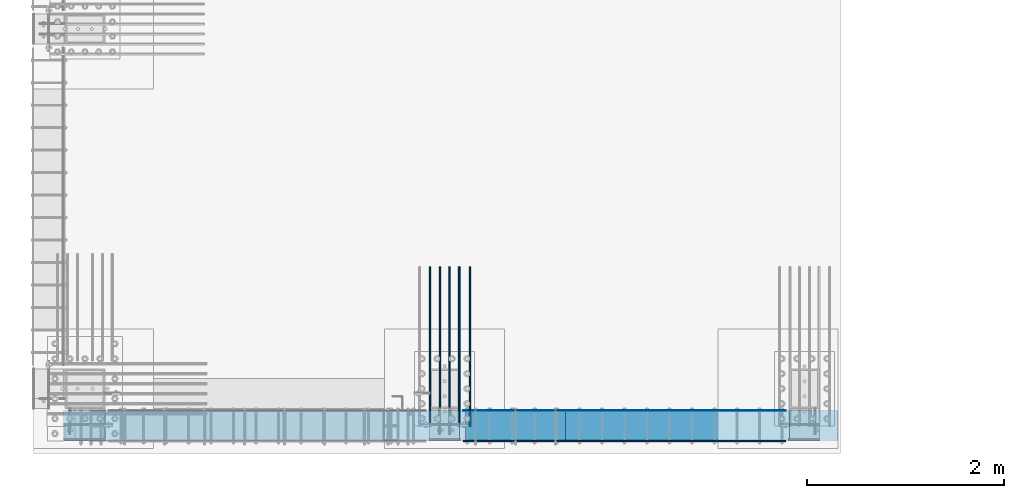
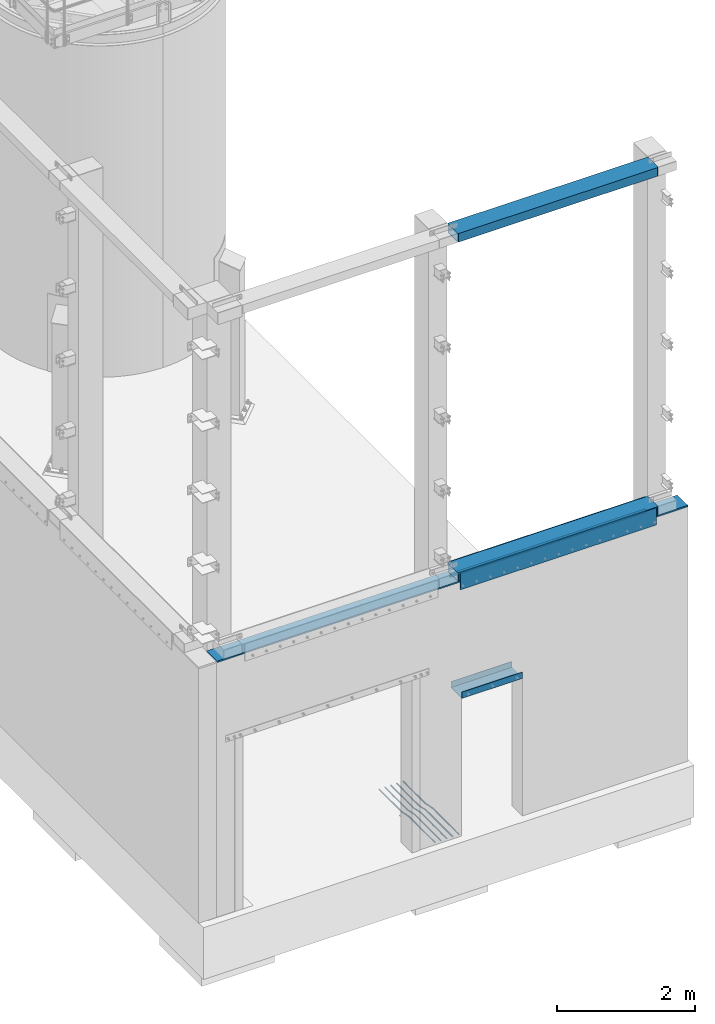
# One storey, part 909 of 1876: 12 beams, 6 elements without a shape of their own.
"""IFC2X3 building model written with IfcOpenShell, lengths in millimetres."""

from ifc_helpers import new_model, si_unit, frame, origin_with_axes, place, context, subcontext, project, spatial, faceted_brep, material, type_object, element, aggregate, save


model = new_model("IFC2X3")

# Units and contexts
model_context = context("Model", 3, precision=1e-05, world=origin_with_axes())
body_context = subcontext(model_context, "Body", "Model", "MODEL_VIEW")
ifc_project = project(units=[si_unit("LENGTHUNIT", "METRE", prefix="MILLI"), si_unit("AREAUNIT", "SQUARE_METRE"), si_unit("VOLUMEUNIT", "CUBIC_METRE"), si_unit("MASSUNIT", "GRAM", prefix="KILO"), si_unit("TIMEUNIT", "SECOND"), si_unit("PLANEANGLEUNIT", "RADIAN"), si_unit("SOLIDANGLEUNIT", "STERADIAN"), si_unit("THERMODYNAMICTEMPERATUREUNIT", "DEGREE_CELSIUS"), si_unit("LUMINOUSINTENSITYUNIT", "LUMEN")], contexts=[model_context])

# Site, building, storey
site_placement = place(None, origin_with_axes())
site = spatial("IfcSite", under=ifc_project, at=site_placement, CompositionType="ELEMENT")
building_placement = place(site_placement, origin_with_axes())
building = spatial("IfcBuilding", under=site, at=building_placement, Name="Undefined", CompositionType="ELEMENT")
storey_placement = place(building_placement, origin_with_axes())
storey = spatial("IfcBuildingStorey", under=building, at=storey_placement, Name="Undefined", CompositionType="ELEMENT", Elevation=0.0)

# Assembly, beam
assembly_1_placement = place(storey_placement, origin_with_axes())
assembly_1 = element("IfcElementAssembly", 1, at=assembly_1_placement, inside=storey, Name="BEAM", AssemblyPlace="NOTDEFINED", PredefinedType="RIGID_FRAME")
ifc_material_1 = material()
beam_type_1 = type_object("IfcBeamType", Name="HSS12X6X1/2", PredefinedType="NOTDEFINED")
beam_1_placement = place(assembly_1_placement, frame((4041.775, -25771.475, 10591.8), z_axis=(0.0, 1.0, 0.0), x_axis=(1.0, 0.0, 0.0)))
beam_1 = element("IfcBeam", 2, at=beam_1_placement, type_object=beam_type_1, material=ifc_material_1, Name="BEAM", ObjectType="HSS12X6X1/2", context=body_context, shape_type="Brep", body=[
    faceted_brep([(0.0, 76.2000000000007, -139.699999999812), (0.0, 63.5, -139.7), (0.0, 63.5, 139.7), (0.0, 76.2000000000007, 139.700000000026), (0.0, -63.5, -139.7), (3352.8, -63.5, -139.7), (3352.8, 63.5, -139.7), (3340.1, 76.2000000000007, -152.4), (3352.8, 76.2000000000007, -139.7), (3352.8, -76.2000000000007, -139.7), (3340.1, -76.2000000000007, -152.4), (12.7000000000025, -76.2000000000007, -152.4), (12.7000000000025, 76.2000000000007, -152.4), (12.6999999999734, 76.2000000000007, 152.4), (3340.1, 76.2000000000007, 152.4), (3352.8, 76.2000000000007, 139.7), (3352.8, 63.5, 139.7), (0.0, -63.5, 139.7), (3352.8, -63.5, 139.7), (0.0, -76.2000000000007, 139.700000000026), (12.6999999999734, -76.2000000000007, 152.4), (3340.1, -76.2000000000007, 152.4), (3352.8, -76.2000000000007, 139.7), (0.0, -76.2000000000007, -139.699999999812)], [[[0, 1, 2, 3]], [[1, 4, 5, 6]], [[7, 8, 6, 5, 9, 10]], [[11, 12, 7, 10]], [[8, 7, 12, 0, 3, 13, 14, 15]], [[6, 8, 15, 16]], [[2, 1, 6, 16]], [[17, 2, 16, 18]], [[3, 2, 17, 19, 20, 13]], [[13, 20, 21, 14]], [[16, 15, 14, 21, 22, 18]], [[9, 5, 18, 22]], [[4, 17, 18, 5]], [[4, 23, 19, 17]], [[20, 19, 23, 11, 10, 9, 22, 21]], [[4, 1, 0, 12, 11, 23]]]),
])
aggregate(assembly_1, [beam_1])

assembly_2_placement = place(storey_placement, origin_with_axes())
assembly_2 = element("IfcElementAssembly", 3, at=assembly_2_placement, inside=storey, Name="BEAM", AssemblyPlace="NOTDEFINED", PredefinedType="RIGID_FRAME")
beam_2_placement = place(assembly_2_placement, frame((4041.775, -25771.475, 4597.4), z_axis=(0.0, 1.0, 0.0), x_axis=(1.0, 0.0, 0.0)))
beam_2 = element("IfcBeam", 4, at=beam_2_placement, type_object=beam_type_1, material=ifc_material_1, Name="BEAM", ObjectType="HSS12X6X1/2", context=body_context, shape_type="Brep", body=[
    faceted_brep([(0.0, -63.5, 139.7), (0.0, 63.5, 139.7), (3352.8, 63.5, 139.7), (3352.8, -63.5, 139.7), (0.0, 76.2000000000007, -139.699999999812), (0.0, 63.5, -139.7), (0.0, 76.2000000000007, 139.700000000026), (0.0, -63.5, -139.7), (12.7000000000025, 76.2000000000007, -152.4), (12.7000000000025, -76.2000000000007, -152.4), (0.0, -76.2000000000007, -139.699999999812), (0.0, -76.2000000000007, 139.700000000026), (12.6999999999734, -76.2000000000007, 152.4), (12.6999999999734, 76.2000000000007, 152.4), (3340.1, -76.2000000000007, 152.4), (3340.1, 76.2000000000007, 152.4), (3352.8, 76.2000000000007, 139.7), (3352.8, -76.2000000000007, 139.7), (3352.8, -76.2000000000007, -139.7), (3352.8, -63.5, -139.7), (3352.8, 63.5, -139.7), (3352.8, 76.2000000000007, -139.7), (3340.1, 76.2000000000007, -152.4), (3340.1, -76.2000000000007, -152.4)], [[[0, 1, 2, 3]], [[4, 5, 1, 6]], [[7, 5, 4, 8, 9, 10]], [[7, 10, 11, 0]], [[6, 1, 0, 11, 12, 13]], [[13, 12, 14, 15]], [[2, 16, 15, 14, 17, 3]], [[18, 19, 3, 17]], [[7, 0, 3, 19]], [[5, 7, 19, 20]], [[1, 5, 20, 2]], [[20, 21, 16, 2]], [[21, 22, 8, 4, 6, 13, 15, 16]], [[9, 8, 22, 23]], [[12, 11, 10, 9, 23, 18, 17, 14]], [[22, 21, 20, 19, 18, 23]]]),
])

# Assembly, beams
assembly_3_placement = place(storey_placement, origin_with_axes())
assembly_3 = element("IfcElementAssembly", 5, at=assembly_3_placement, inside=storey, Name="PLATE", AssemblyPlace="NOTDEFINED", PredefinedType="RIGID_FRAME")
ifc_material_2 = material(Name="STEEL/A36")
beam_type_2 = type_object("IfcBeamType", PredefinedType="NOTDEFINED")
beam_3_placement = place(assembly_3_placement, frame((7356.47500038147, -25623.044, 4432.3), z_axis=(0.0, 0.0, 1.0), x_axis=(-1.0, 0.0, 0.0)))
beam_3 = element("IfcBeam", 6, at=beam_3_placement, type_object=beam_type_2, material=ifc_material_2, Name="PLATE", context=body_context, shape_type="Brep", body=[
    faceted_brep([(0.0, 3.969, -38.1000000000004), (0.0, 3.969, 38.1000000000004), (3276.6, 3.96900000000096, 38.1000000000004), (3276.6, 3.96900000000096, -38.1000000000004), (0.0, -3.969, 38.1000000000004), (3276.6, -3.96900000000096, 38.1000000000004), (0.0, -3.969, -38.1000000000004), (3276.6, -3.96900000000096, -38.1000000000004)], [[[0, 1, 2, 3]], [[1, 4, 5, 2]], [[4, 6, 7, 5]], [[6, 0, 3, 7]], [[5, 7, 3, 2]], [[6, 4, 1, 0]]]),
])
beam_type_3 = type_object("IfcBeamType", PredefinedType="NOTDEFINED")
beam_4_placement = place(assembly_3_placement, frame((7356.475, -25612.725, 4521.2), z_axis=(0.0, 0.0, 1.0), x_axis=(-1.0, 0.0, 0.0)))
beam_4 = element("IfcBeam", 7, at=beam_4_placement, type_object=beam_type_3, material=ifc_material_2, Name="PLATE", context=body_context, shape_type="Brep", body=[
    faceted_brep([(0.0, 6.35000000000002, -152.4), (0.0, 6.35000000000002, 152.4), (3276.6, 6.35000000000002, 152.4), (3276.6, 6.35000000000002, -152.4), (0.0, -6.35000000000002, 152.4), (3276.6, -6.35000000000002, 152.4), (0.0, -6.35000000000002, -152.4), (3276.6, -6.35000000000002, -152.4)], [[[0, 1, 2, 3]], [[1, 4, 5, 2]], [[4, 6, 7, 5]], [[6, 0, 3, 7]], [[5, 7, 3, 2]], [[6, 4, 1, 0]]]),
])
aggregate(assembly_3, [beam_3, beam_4])

# Beam
beam_5_placement = place(assembly_2_placement, frame((7356.475, -25930.225, 4521.2), z_axis=(0.0, 0.0, 1.0), x_axis=(-1.0, 0.0, 0.0)))
beam_5 = element("IfcBeam", 8, at=beam_5_placement, type_object=beam_type_3, material=ifc_material_2, Name="PLATE", context=body_context, shape_type="Brep", body=[
    faceted_brep([(0.0, 6.35000000000002, -152.4), (0.0, 6.35000000000002, 152.4), (3276.6, 6.35000000000002, 152.4), (3276.6, 6.35000000000002, -152.4), (0.0, -6.35000000000002, 152.4), (3276.6, -6.35000000000002, 152.4), (0.0, -6.35000000000002, -152.4), (3276.6, -6.35000000000002, -152.4)], [[[0, 1, 2, 3]], [[1, 4, 5, 2]], [[4, 6, 7, 5]], [[6, 0, 3, 7]], [[5, 7, 3, 2]], [[6, 4, 1, 0]]]),
])

aggregate(assembly_2, [beam_5, beam_2])

# Assembly, beams
assembly_4_placement = place(storey_placement, origin_with_axes())
assembly_4 = element("IfcElementAssembly", 9, at=assembly_4_placement, inside=storey, Name="PLATE", AssemblyPlace="NOTDEFINED", PredefinedType="RIGID_FRAME")
ifc_material_3 = material(Name="STEEL/A706-GR.60")
beam_type_4 = type_object("IfcBeamType", Name="5 REBAR", PredefinedType="NOTDEFINED")
beam_6_placement = place(assembly_4_placement, frame((3741.73752441406, -25781.0, -71.4374999999993), z_axis=(-1.0, 0.0, 0.0), x_axis=(0.0, 1.0, 0.0)))
beam_6 = element("IfcBeam", 10, at=beam_6_placement, type_object=beam_type_4, material=ifc_material_3, Name="REBAR", ObjectType="5 REBAR", context=body_context, shape_type="Brep", body=[
    faceted_brep([(0.0, -7.9375, 0.0), (0.0, -5.61266007566822, -5.61266007566883), (760.672013570867, -5.61266007566822, -5.61266007566837), (760.672013570867, -7.9375, 0.0), (0.0, 0.0, -7.9375), (760.672013570867, 0.0, -7.9375), (0.0, 5.61266007566822, -5.61266007566883), (760.672013570867, 5.61266007566822, -5.61266007566837), (0.0, 7.9375, 0.0), (760.672013570867, 7.9375, 0.0), (0.0, 5.61266007566822, 5.61266007566883), (760.672013570867, 5.61266007566822, 5.61266007566837), (0.0, 0.0, 7.9375), (760.672013570867, 0.0, 7.9375), (0.0, -5.61266007566822, 5.61266007566883), (760.672013570867, -5.61266007566822, 5.61266007566837), (762.585579012299, -5.61266007566822, -5.61266007566837), (762.828108499445, -7.9375, 0.0), (762.000061035156, 0.0, -7.9375), (761.414543058014, 5.61266007566822, -5.61266007566837), (761.172013570867, 7.9375, 0.0), (761.414543058014, 5.61266007566822, 5.61266007566837), (762.000061035156, 0.0, 7.9375), (762.585579012299, -5.61266007566822, 5.61266007566837), (764.4579427221, -5.21770838638834, -5.61266007566837), (764.937779698426, -7.49249126611924, 0.0), (763.299513786125, 0.274103293312095, -7.9375), (762.141084850151, 5.76591497301254, -5.61266007566837), (761.661247873824, 8.04069785274343, 0.0), (762.141084850151, 5.76591497301254, 5.61266007566837), (763.299513786125, 0.274103293312095, 7.9375), (764.4579427221, -5.21770838638834, 5.61266007566837), (965.059049427193, 37.096584264048, -5.61266007566837), (965.538886403519, 34.8218013843171, 0.0), (963.900620491218, 42.5883959437484, -7.9375), (962.742191555244, 48.0802076234489, -5.61266007566837), (962.262354578917, 50.3549905031798, 0.0), (962.742191555244, 48.0802076234489, 5.61266007566837), (963.900620491218, 42.5883959437484, 7.9375), (965.059049427193, 37.096584264048, 5.61266007566837), (965.78559121933, 37.2498391613923, -5.61266007566837), (966.028120706476, 34.9249992370605, 0.0), (965.200073242188, 42.8624992370605, -7.9375), (964.614555265045, 48.4751593127288, -5.61266007566837), (964.372025777899, 50.7999992370606, 0.0), (964.614555265045, 48.4751593127288, 5.61266007566837), (965.200073242188, 42.8624992370605, 7.9375), (965.78559121933, 37.2498391613923, 5.61266007566837), (966.528120706476, 37.2498391613923, -5.61266007566837), (966.528120706476, 34.9249992370605, 0.0), (966.528120706476, 42.8624992370605, -7.9375), (966.528120706476, 48.4751593127288, -5.61266007566837), (966.528120706476, 50.7999992370605, 0.0), (966.528120706476, 48.4751593127288, 5.61266007566837), (966.528120706476, 42.8624992370605, 7.9375), (966.528120706476, 37.2498391613923, 5.61266007566837), (1619.25, 37.2498391613923, -5.61266007566837), (1619.25, 34.9249992370605, 0.0), (1619.25, 42.8624992370605, -7.9375), (1619.25, 48.4751593127288, -5.61266007566837), (1619.25, 50.7999992370605, 0.0), (1619.25, 48.4751593127288, 5.61266007566837), (1619.25, 42.8624992370605, 7.9375), (1619.25, 37.2498391613923, 5.61266007566837)], [[[0, 1, 2, 3]], [[1, 4, 5, 2]], [[4, 6, 7, 5]], [[6, 8, 9, 7]], [[8, 10, 11, 9]], [[10, 12, 13, 11]], [[12, 14, 15, 13]], [[14, 0, 3, 15]], [[14, 12, 10, 8, 6, 4, 1, 0]], [[3, 2, 16, 17]], [[2, 5, 18, 16]], [[5, 7, 19, 18]], [[7, 9, 20, 19]], [[9, 11, 21, 20]], [[11, 13, 22, 21]], [[13, 15, 23, 22]], [[15, 3, 17, 23]], [[17, 16, 24, 25]], [[16, 18, 26, 24]], [[18, 19, 27, 26]], [[19, 20, 28, 27]], [[20, 21, 29, 28]], [[21, 22, 30, 29]], [[22, 23, 31, 30]], [[23, 17, 25, 31]], [[25, 24, 32, 33]], [[24, 26, 34, 32]], [[26, 27, 35, 34]], [[27, 28, 36, 35]], [[28, 29, 37, 36]], [[29, 30, 38, 37]], [[30, 31, 39, 38]], [[31, 25, 33, 39]], [[33, 32, 40, 41]], [[32, 34, 42, 40]], [[34, 35, 43, 42]], [[35, 36, 44, 43]], [[36, 37, 45, 44]], [[37, 38, 46, 45]], [[38, 39, 47, 46]], [[39, 33, 41, 47]], [[41, 40, 48, 49]], [[40, 42, 50, 48]], [[42, 43, 51, 50]], [[43, 44, 52, 51]], [[44, 45, 53, 52]], [[45, 46, 54, 53]], [[46, 47, 55, 54]], [[47, 41, 49, 55]], [[49, 48, 56, 57]], [[48, 50, 58, 56]], [[50, 51, 59, 58]], [[51, 52, 60, 59]], [[52, 53, 61, 60]], [[53, 54, 62, 61]], [[54, 55, 63, 62]], [[55, 49, 57, 63]], [[58, 59, 60, 61, 62, 63, 57, 56]]]),
])
beam_7_placement = place(assembly_4_placement, frame((4144.9625, -25781.0, -71.4374999999993), z_axis=(-1.0, 0.0, 0.0), x_axis=(0.0, 1.0, 0.0)))
beam_7 = element("IfcBeam", 11, at=beam_7_placement, type_object=beam_type_4, material=ifc_material_3, Name="REBAR", ObjectType="5 REBAR", context=body_context, shape_type="Brep", body=[
    faceted_brep([(0.0, -7.9375, 0.0), (0.0, -5.61266007566822, -5.61266007566883), (760.672013570867, -5.61266007566822, -5.61266007566837), (760.672013570867, -7.9375, 0.0), (0.0, 0.0, -7.9375), (760.672013570867, 0.0, -7.9375), (0.0, 5.61266007566822, -5.61266007566883), (760.672013570867, 5.61266007566822, -5.61266007566837), (0.0, 7.9375, 0.0), (760.672013570867, 7.9375, 0.0), (0.0, 5.61266007566822, 5.61266007566883), (760.672013570867, 5.61266007566822, 5.61266007566837), (0.0, 0.0, 7.9375), (760.672013570867, 0.0, 7.9375), (0.0, -5.61266007566822, 5.61266007566883), (760.672013570867, -5.61266007566822, 5.61266007566837), (762.585579012299, -5.61266007566822, -5.61266007566837), (762.828108499445, -7.9375, 0.0), (762.000061035156, 0.0, -7.9375), (761.414543058014, 5.61266007566822, -5.61266007566837), (761.172013570867, 7.9375, 0.0), (761.414543058014, 5.61266007566822, 5.61266007566837), (762.000061035156, 0.0, 7.9375), (762.585579012299, -5.61266007566822, 5.61266007566837), (764.4579427221, -5.21770838638834, -5.61266007566837), (764.937779698426, -7.49249126611924, 0.0), (763.299513786125, 0.274103293312095, -7.9375), (762.141084850151, 5.76591497301254, -5.61266007566837), (761.661247873824, 8.04069785274343, 0.0), (762.141084850151, 5.76591497301254, 5.61266007566837), (763.299513786125, 0.274103293312095, 7.9375), (764.4579427221, -5.21770838638834, 5.61266007566837), (965.059049427193, 37.096584264048, -5.61266007566837), (965.538886403519, 34.8218013843171, 0.0), (963.900620491218, 42.5883959437484, -7.9375), (962.742191555244, 48.0802076234489, -5.61266007566837), (962.262354578917, 50.3549905031798, 0.0), (962.742191555244, 48.0802076234489, 5.61266007566837), (963.900620491218, 42.5883959437484, 7.9375), (965.059049427193, 37.096584264048, 5.61266007566837), (965.78559121933, 37.2498391613923, -5.61266007566837), (966.028120706476, 34.9249992370605, 0.0), (965.200073242188, 42.8624992370605, -7.9375), (964.614555265045, 48.4751593127288, -5.61266007566837), (964.372025777899, 50.7999992370606, 0.0), (964.614555265045, 48.4751593127288, 5.61266007566837), (965.200073242188, 42.8624992370605, 7.9375), (965.78559121933, 37.2498391613923, 5.61266007566837), (966.528120706476, 37.2498391613923, -5.61266007566837), (966.528120706476, 34.9249992370605, 0.0), (966.528120706476, 42.8624992370605, -7.9375), (966.528120706476, 48.4751593127288, -5.61266007566837), (966.528120706476, 50.7999992370605, 0.0), (966.528120706476, 48.4751593127288, 5.61266007566837), (966.528120706476, 42.8624992370605, 7.9375), (966.528120706476, 37.2498391613923, 5.61266007566837), (1619.25, 37.2498391613923, -5.61266007566837), (1619.25, 34.9249992370605, 0.0), (1619.25, 42.8624992370605, -7.9375), (1619.25, 48.4751593127288, -5.61266007566837), (1619.25, 50.7999992370605, 0.0), (1619.25, 48.4751593127288, 5.61266007566837), (1619.25, 42.8624992370605, 7.9375), (1619.25, 37.2498391613923, 5.61266007566837)], [[[0, 1, 2, 3]], [[1, 4, 5, 2]], [[4, 6, 7, 5]], [[6, 8, 9, 7]], [[8, 10, 11, 9]], [[10, 12, 13, 11]], [[12, 14, 15, 13]], [[14, 0, 3, 15]], [[14, 12, 10, 8, 6, 4, 1, 0]], [[3, 2, 16, 17]], [[2, 5, 18, 16]], [[5, 7, 19, 18]], [[7, 9, 20, 19]], [[9, 11, 21, 20]], [[11, 13, 22, 21]], [[13, 15, 23, 22]], [[15, 3, 17, 23]], [[17, 16, 24, 25]], [[16, 18, 26, 24]], [[18, 19, 27, 26]], [[19, 20, 28, 27]], [[20, 21, 29, 28]], [[21, 22, 30, 29]], [[22, 23, 31, 30]], [[23, 17, 25, 31]], [[25, 24, 32, 33]], [[24, 26, 34, 32]], [[26, 27, 35, 34]], [[27, 28, 36, 35]], [[28, 29, 37, 36]], [[29, 30, 38, 37]], [[30, 31, 39, 38]], [[31, 25, 33, 39]], [[33, 32, 40, 41]], [[32, 34, 42, 40]], [[34, 35, 43, 42]], [[35, 36, 44, 43]], [[36, 37, 45, 44]], [[37, 38, 46, 45]], [[38, 39, 47, 46]], [[39, 33, 41, 47]], [[41, 40, 48, 49]], [[40, 42, 50, 48]], [[42, 43, 51, 50]], [[43, 44, 52, 51]], [[44, 45, 53, 52]], [[45, 46, 54, 53]], [[46, 47, 55, 54]], [[47, 41, 49, 55]], [[49, 48, 56, 57]], [[48, 50, 58, 56]], [[50, 51, 59, 58]], [[51, 52, 60, 59]], [[52, 53, 61, 60]], [[53, 54, 62, 61]], [[54, 55, 63, 62]], [[55, 49, 57, 63]], [[58, 59, 60, 61, 62, 63, 57, 56]]]),
])
beam_8_placement = place(assembly_4_placement, frame((4037.0125, -25781.0, -71.4374999999993), z_axis=(-1.0, 0.0, 0.0), x_axis=(0.0, 1.0, 0.0)))
beam_8 = element("IfcBeam", 12, at=beam_8_placement, type_object=beam_type_4, material=ifc_material_3, Name="REBAR", ObjectType="5 REBAR", context=body_context, shape_type="Brep", body=[
    faceted_brep([(0.0, -7.9375, 0.0), (0.0, -5.61266007566822, -5.61266007566883), (760.672013570867, -5.61266007566822, -5.61266007566837), (760.672013570867, -7.9375, 0.0), (0.0, 0.0, -7.9375), (760.672013570867, 0.0, -7.9375), (0.0, 5.61266007566822, -5.61266007566883), (760.672013570867, 5.61266007566822, -5.61266007566837), (0.0, 7.9375, 0.0), (760.672013570867, 7.9375, 0.0), (0.0, 5.61266007566822, 5.61266007566883), (760.672013570867, 5.61266007566822, 5.61266007566837), (0.0, 0.0, 7.9375), (760.672013570867, 0.0, 7.9375), (0.0, -5.61266007566822, 5.61266007566883), (760.672013570867, -5.61266007566822, 5.61266007566837), (762.585579012299, -5.61266007566822, -5.61266007566837), (762.828108499445, -7.9375, 0.0), (762.000061035156, 0.0, -7.9375), (761.414543058014, 5.61266007566822, -5.61266007566837), (761.172013570867, 7.9375, 0.0), (761.414543058014, 5.61266007566822, 5.61266007566837), (762.000061035156, 0.0, 7.9375), (762.585579012299, -5.61266007566822, 5.61266007566837), (764.4579427221, -5.21770838638834, -5.61266007566837), (764.937779698426, -7.49249126611924, 0.0), (763.299513786125, 0.274103293312095, -7.9375), (762.141084850151, 5.76591497301254, -5.61266007566837), (761.661247873824, 8.04069785274343, 0.0), (762.141084850151, 5.76591497301254, 5.61266007566837), (763.299513786125, 0.274103293312095, 7.9375), (764.4579427221, -5.21770838638834, 5.61266007566837), (965.059049427193, 37.096584264048, -5.61266007566837), (965.538886403519, 34.8218013843171, 0.0), (963.900620491218, 42.5883959437484, -7.9375), (962.742191555244, 48.0802076234489, -5.61266007566837), (962.262354578917, 50.3549905031798, 0.0), (962.742191555244, 48.0802076234489, 5.61266007566837), (963.900620491218, 42.5883959437484, 7.9375), (965.059049427193, 37.096584264048, 5.61266007566837), (965.78559121933, 37.2498391613923, -5.61266007566837), (966.028120706476, 34.9249992370605, 0.0), (965.200073242188, 42.8624992370605, -7.9375), (964.614555265045, 48.4751593127288, -5.61266007566837), (964.372025777899, 50.7999992370606, 0.0), (964.614555265045, 48.4751593127288, 5.61266007566837), (965.200073242188, 42.8624992370605, 7.9375), (965.78559121933, 37.2498391613923, 5.61266007566837), (966.528120706476, 37.2498391613923, -5.61266007566837), (966.528120706476, 34.9249992370605, 0.0), (966.528120706476, 42.8624992370605, -7.9375), (966.528120706476, 48.4751593127288, -5.61266007566837), (966.528120706476, 50.7999992370605, 0.0), (966.528120706476, 48.4751593127288, 5.61266007566837), (966.528120706476, 42.8624992370605, 7.9375), (966.528120706476, 37.2498391613923, 5.61266007566837), (1619.25, 37.2498391613923, -5.61266007566837), (1619.25, 34.9249992370605, 0.0), (1619.25, 42.8624992370605, -7.9375), (1619.25, 48.4751593127288, -5.61266007566837), (1619.25, 50.7999992370605, 0.0), (1619.25, 48.4751593127288, 5.61266007566837), (1619.25, 42.8624992370605, 7.9375), (1619.25, 37.2498391613923, 5.61266007566837)], [[[0, 1, 2, 3]], [[1, 4, 5, 2]], [[4, 6, 7, 5]], [[6, 8, 9, 7]], [[8, 10, 11, 9]], [[10, 12, 13, 11]], [[12, 14, 15, 13]], [[14, 0, 3, 15]], [[14, 12, 10, 8, 6, 4, 1, 0]], [[3, 2, 16, 17]], [[2, 5, 18, 16]], [[5, 7, 19, 18]], [[7, 9, 20, 19]], [[9, 11, 21, 20]], [[11, 13, 22, 21]], [[13, 15, 23, 22]], [[15, 3, 17, 23]], [[17, 16, 24, 25]], [[16, 18, 26, 24]], [[18, 19, 27, 26]], [[19, 20, 28, 27]], [[20, 21, 29, 28]], [[21, 22, 30, 29]], [[22, 23, 31, 30]], [[23, 17, 25, 31]], [[25, 24, 32, 33]], [[24, 26, 34, 32]], [[26, 27, 35, 34]], [[27, 28, 36, 35]], [[28, 29, 37, 36]], [[29, 30, 38, 37]], [[30, 31, 39, 38]], [[31, 25, 33, 39]], [[33, 32, 40, 41]], [[32, 34, 42, 40]], [[34, 35, 43, 42]], [[35, 36, 44, 43]], [[36, 37, 45, 44]], [[37, 38, 46, 45]], [[38, 39, 47, 46]], [[39, 33, 41, 47]], [[41, 40, 48, 49]], [[40, 42, 50, 48]], [[42, 43, 51, 50]], [[43, 44, 52, 51]], [[44, 45, 53, 52]], [[45, 46, 54, 53]], [[46, 47, 55, 54]], [[47, 41, 49, 55]], [[49, 48, 56, 57]], [[48, 50, 58, 56]], [[50, 51, 59, 58]], [[51, 52, 60, 59]], [[52, 53, 61, 60]], [[53, 54, 62, 61]], [[54, 55, 63, 62]], [[55, 49, 57, 63]], [[58, 59, 60, 61, 62, 63, 57, 56]]]),
])
beam_9_placement = place(assembly_4_placement, frame((3938.58750813802, -25781.0, -71.4374999999993), z_axis=(-1.0, 0.0, 0.0), x_axis=(0.0, 1.0, 0.0)))
beam_9 = element("IfcBeam", 13, at=beam_9_placement, type_object=beam_type_4, material=ifc_material_3, Name="REBAR", ObjectType="5 REBAR", context=body_context, shape_type="Brep", body=[
    faceted_brep([(0.0, -7.9375, 0.0), (0.0, -5.61266007566822, -5.61266007566883), (760.672013570867, -5.61266007566822, -5.61266007566837), (760.672013570867, -7.9375, 0.0), (0.0, 0.0, -7.9375), (760.672013570867, 0.0, -7.9375), (0.0, 5.61266007566822, -5.61266007566883), (760.672013570867, 5.61266007566822, -5.61266007566837), (0.0, 7.9375, 0.0), (760.672013570867, 7.9375, 0.0), (0.0, 5.61266007566822, 5.61266007566883), (760.672013570867, 5.61266007566822, 5.61266007566837), (0.0, 0.0, 7.9375), (760.672013570867, 0.0, 7.9375), (0.0, -5.61266007566822, 5.61266007566883), (760.672013570867, -5.61266007566822, 5.61266007566837), (762.585579012299, -5.61266007566822, -5.61266007566837), (762.828108499445, -7.9375, 0.0), (762.000061035156, 0.0, -7.9375), (761.414543058014, 5.61266007566822, -5.61266007566837), (761.172013570867, 7.9375, 0.0), (761.414543058014, 5.61266007566822, 5.61266007566837), (762.000061035156, 0.0, 7.9375), (762.585579012299, -5.61266007566822, 5.61266007566837), (764.4579427221, -5.21770838638834, -5.61266007566837), (764.937779698426, -7.49249126611924, 0.0), (763.299513786125, 0.274103293312095, -7.9375), (762.141084850151, 5.76591497301254, -5.61266007566837), (761.661247873824, 8.04069785274343, 0.0), (762.141084850151, 5.76591497301254, 5.61266007566837), (763.299513786125, 0.274103293312095, 7.9375), (764.4579427221, -5.21770838638834, 5.61266007566837), (965.059049427193, 37.096584264048, -5.61266007566837), (965.538886403519, 34.8218013843171, 0.0), (963.900620491218, 42.5883959437484, -7.9375), (962.742191555244, 48.0802076234489, -5.61266007566837), (962.262354578917, 50.3549905031798, 0.0), (962.742191555244, 48.0802076234489, 5.61266007566837), (963.900620491218, 42.5883959437484, 7.9375), (965.059049427193, 37.096584264048, 5.61266007566837), (965.78559121933, 37.2498391613923, -5.61266007566837), (966.028120706476, 34.9249992370605, 0.0), (965.200073242188, 42.8624992370605, -7.9375), (964.614555265045, 48.4751593127288, -5.61266007566837), (964.372025777899, 50.7999992370606, 0.0), (964.614555265045, 48.4751593127288, 5.61266007566837), (965.200073242188, 42.8624992370605, 7.9375), (965.78559121933, 37.2498391613923, 5.61266007566837), (966.528120706476, 37.2498391613923, -5.61266007566837), (966.528120706476, 34.9249992370605, 0.0), (966.528120706476, 42.8624992370605, -7.9375), (966.528120706476, 48.4751593127288, -5.61266007566837), (966.528120706476, 50.7999992370605, 0.0), (966.528120706476, 48.4751593127288, 5.61266007566837), (966.528120706476, 42.8624992370605, 7.9375), (966.528120706476, 37.2498391613923, 5.61266007566837), (1619.25, 37.2498391613923, -5.61266007566837), (1619.25, 34.9249992370605, 0.0), (1619.25, 42.8624992370605, -7.9375), (1619.25, 48.4751593127288, -5.61266007566837), (1619.25, 50.7999992370605, 0.0), (1619.25, 48.4751593127288, 5.61266007566837), (1619.25, 42.8624992370605, 7.9375), (1619.25, 37.2498391613923, 5.61266007566837)], [[[0, 1, 2, 3]], [[1, 4, 5, 2]], [[4, 6, 7, 5]], [[6, 8, 9, 7]], [[8, 10, 11, 9]], [[10, 12, 13, 11]], [[12, 14, 15, 13]], [[14, 0, 3, 15]], [[14, 12, 10, 8, 6, 4, 1, 0]], [[3, 2, 16, 17]], [[2, 5, 18, 16]], [[5, 7, 19, 18]], [[7, 9, 20, 19]], [[9, 11, 21, 20]], [[11, 13, 22, 21]], [[13, 15, 23, 22]], [[15, 3, 17, 23]], [[17, 16, 24, 25]], [[16, 18, 26, 24]], [[18, 19, 27, 26]], [[19, 20, 28, 27]], [[20, 21, 29, 28]], [[21, 22, 30, 29]], [[22, 23, 31, 30]], [[23, 17, 25, 31]], [[25, 24, 32, 33]], [[24, 26, 34, 32]], [[26, 27, 35, 34]], [[27, 28, 36, 35]], [[28, 29, 37, 36]], [[29, 30, 38, 37]], [[30, 31, 39, 38]], [[31, 25, 33, 39]], [[33, 32, 40, 41]], [[32, 34, 42, 40]], [[34, 35, 43, 42]], [[35, 36, 44, 43]], [[36, 37, 45, 44]], [[37, 38, 46, 45]], [[38, 39, 47, 46]], [[39, 33, 41, 47]], [[41, 40, 48, 49]], [[40, 42, 50, 48]], [[42, 43, 51, 50]], [[43, 44, 52, 51]], [[44, 45, 53, 52]], [[45, 46, 54, 53]], [[46, 47, 55, 54]], [[47, 41, 49, 55]], [[49, 48, 56, 57]], [[48, 50, 58, 56]], [[50, 51, 59, 58]], [[51, 52, 60, 59]], [[52, 53, 61, 60]], [[53, 54, 62, 61]], [[54, 55, 63, 62]], [[55, 49, 57, 63]], [[58, 59, 60, 61, 62, 63, 57, 56]]]),
])
beam_10_placement = place(assembly_4_placement, frame((3840.16251627604, -25781.0, -71.4374999999993), z_axis=(-1.0, 0.0, 0.0), x_axis=(0.0, 1.0, 0.0)))
beam_10 = element("IfcBeam", 14, at=beam_10_placement, type_object=beam_type_4, material=ifc_material_3, Name="REBAR", ObjectType="5 REBAR", context=body_context, shape_type="Brep", body=[
    faceted_brep([(0.0, -7.9375, 0.0), (0.0, -5.61266007566822, -5.61266007566883), (760.672013570867, -5.61266007566822, -5.61266007566837), (760.672013570867, -7.9375, 0.0), (0.0, 0.0, -7.9375), (760.672013570867, 0.0, -7.9375), (0.0, 5.61266007566822, -5.61266007566883), (760.672013570867, 5.61266007566822, -5.61266007566837), (0.0, 7.9375, 0.0), (760.672013570867, 7.9375, 0.0), (0.0, 5.61266007566822, 5.61266007566883), (760.672013570867, 5.61266007566822, 5.61266007566837), (0.0, 0.0, 7.9375), (760.672013570867, 0.0, 7.9375), (0.0, -5.61266007566822, 5.61266007566883), (760.672013570867, -5.61266007566822, 5.61266007566837), (762.585579012299, -5.61266007566822, -5.61266007566837), (762.828108499445, -7.9375, 0.0), (762.000061035156, 0.0, -7.9375), (761.414543058014, 5.61266007566822, -5.61266007566837), (761.172013570867, 7.9375, 0.0), (761.414543058014, 5.61266007566822, 5.61266007566837), (762.000061035156, 0.0, 7.9375), (762.585579012299, -5.61266007566822, 5.61266007566837), (764.4579427221, -5.21770838638834, -5.61266007566837), (764.937779698426, -7.49249126611924, 0.0), (763.299513786125, 0.274103293312095, -7.9375), (762.141084850151, 5.76591497301254, -5.61266007566837), (761.661247873824, 8.04069785274343, 0.0), (762.141084850151, 5.76591497301254, 5.61266007566837), (763.299513786125, 0.274103293312095, 7.9375), (764.4579427221, -5.21770838638834, 5.61266007566837), (965.059049427193, 37.096584264048, -5.61266007566837), (965.538886403519, 34.8218013843171, 0.0), (963.900620491218, 42.5883959437484, -7.9375), (962.742191555244, 48.0802076234489, -5.61266007566837), (962.262354578917, 50.3549905031798, 0.0), (962.742191555244, 48.0802076234489, 5.61266007566837), (963.900620491218, 42.5883959437484, 7.9375), (965.059049427193, 37.096584264048, 5.61266007566837), (965.78559121933, 37.2498391613923, -5.61266007566837), (966.028120706476, 34.9249992370605, 0.0), (965.200073242188, 42.8624992370605, -7.9375), (964.614555265045, 48.4751593127288, -5.61266007566837), (964.372025777899, 50.7999992370606, 0.0), (964.614555265045, 48.4751593127288, 5.61266007566837), (965.200073242188, 42.8624992370605, 7.9375), (965.78559121933, 37.2498391613923, 5.61266007566837), (966.528120706476, 37.2498391613923, -5.61266007566837), (966.528120706476, 34.9249992370605, 0.0), (966.528120706476, 42.8624992370605, -7.9375), (966.528120706476, 48.4751593127288, -5.61266007566837), (966.528120706476, 50.7999992370605, 0.0), (966.528120706476, 48.4751593127288, 5.61266007566837), (966.528120706476, 42.8624992370605, 7.9375), (966.528120706476, 37.2498391613923, 5.61266007566837), (1619.25, 37.2498391613923, -5.61266007566837), (1619.25, 34.9249992370605, 0.0), (1619.25, 42.8624992370605, -7.9375), (1619.25, 48.4751593127288, -5.61266007566837), (1619.25, 50.7999992370605, 0.0), (1619.25, 48.4751593127288, 5.61266007566837), (1619.25, 42.8624992370605, 7.9375), (1619.25, 37.2498391613923, 5.61266007566837)], [[[0, 1, 2, 3]], [[1, 4, 5, 2]], [[4, 6, 7, 5]], [[6, 8, 9, 7]], [[8, 10, 11, 9]], [[10, 12, 13, 11]], [[12, 14, 15, 13]], [[14, 0, 3, 15]], [[14, 12, 10, 8, 6, 4, 1, 0]], [[3, 2, 16, 17]], [[2, 5, 18, 16]], [[5, 7, 19, 18]], [[7, 9, 20, 19]], [[9, 11, 21, 20]], [[11, 13, 22, 21]], [[13, 15, 23, 22]], [[15, 3, 17, 23]], [[17, 16, 24, 25]], [[16, 18, 26, 24]], [[18, 19, 27, 26]], [[19, 20, 28, 27]], [[20, 21, 29, 28]], [[21, 22, 30, 29]], [[22, 23, 31, 30]], [[23, 17, 25, 31]], [[25, 24, 32, 33]], [[24, 26, 34, 32]], [[26, 27, 35, 34]], [[27, 28, 36, 35]], [[28, 29, 37, 36]], [[29, 30, 38, 37]], [[30, 31, 39, 38]], [[31, 25, 33, 39]], [[33, 32, 40, 41]], [[32, 34, 42, 40]], [[34, 35, 43, 42]], [[35, 36, 44, 43]], [[36, 37, 45, 44]], [[37, 38, 46, 45]], [[38, 39, 47, 46]], [[39, 33, 41, 47]], [[41, 40, 48, 49]], [[40, 42, 50, 48]], [[42, 43, 51, 50]], [[43, 44, 52, 51]], [[44, 45, 53, 52]], [[45, 46, 54, 53]], [[46, 47, 55, 54]], [[47, 41, 49, 55]], [[49, 48, 56, 57]], [[48, 50, 58, 56]], [[50, 51, 59, 58]], [[51, 52, 60, 59]], [[52, 53, 61, 60]], [[53, 54, 62, 61]], [[54, 55, 63, 62]], [[55, 49, 57, 63]], [[58, 59, 60, 61, 62, 63, 57, 56]]]),
])
aggregate(assembly_4, [beam_6, beam_7, beam_8, beam_9, beam_10])

# Assembly, beam
assembly_5_placement = place(storey_placement, origin_with_axes())
assembly_5 = element("IfcElementAssembly", 15, at=assembly_5_placement, inside=storey, Name="EXPANSION JOINT", AssemblyPlace="NOTDEFINED", PredefinedType="RIGID_FRAME")
ifc_material_4 = material(Name="STEEL/Steel_Undefined")
beam_type_5 = type_object("IfcBeamType", PredefinedType="NOTDEFINED")
beam_11_placement = place(assembly_5_placement, frame((12.6999999999992, -25771.475, 4508.5), z_axis=(0.0, 1.0, 0.0), x_axis=(1.0, 0.0, 0.0)))
beam_11 = element("IfcBeam", 16, at=beam_11_placement, type_object=beam_type_5, material=ifc_material_4, Name="EXPANSION JOINT", context=body_context, shape_type="Brep", body=[
    faceted_brep([(0.0, 12.6999999999998, -152.400000000001), (0.0, 12.6999999999998, 152.400000000001), (7873.9998046875, 12.6999999999998, 152.400000000001), (7873.9998046875, 12.6999999999998, -152.400000000001), (0.0, -12.6999999999998, 152.400000000001), (7873.9998046875, -12.6999999999998, 152.400000000001), (0.0, -12.6999999999998, -152.400000000001), (7873.9998046875, -12.6999999999998, -152.400000000001)], [[[0, 1, 2, 3]], [[1, 4, 5, 2]], [[4, 6, 7, 5]], [[6, 0, 3, 7]], [[5, 7, 3, 2]], [[6, 4, 1, 0]]]),
])
aggregate(assembly_5, [beam_11])

assembly_6_placement = place(storey_placement, origin_with_axes())
assembly_6 = element("IfcElementAssembly", 17, at=assembly_6_placement, inside=storey, Name="BENT PLATE", AssemblyPlace="NOTDEFINED", PredefinedType="RIGID_FRAME")
beam_type_6 = type_object("IfcBeamType", PredefinedType="NOTDEFINED")
beam_12_placement = place(assembly_6_placement, frame((4610.1, -25928.6375, 2549.52490234375), z_axis=(1.0, 0.0, 0.0), x_axis=(0.0, 0.0, -1.0)))
beam_12 = element("IfcBeam", 18, at=beam_12_placement, type_object=beam_type_6, material=ifc_material_2, Name="BENT PLATE", context=body_context, shape_type="Brep", body=[
    faceted_brep([(0.0, -4.76250000000073, -508.0), (0.0, -4.76250000000073, 508.0), (0.0, 4.76250000000073, 508.0), (0.0, 4.76250000000073, -508.0), (101.599998474122, 4.76250000000073, 508.0), (101.599998474122, 4.76250000000073, -508.0), (111.124998474122, -4.76250000000073, -508.0), (111.124998474122, -4.76250000000073, 508.0), (101.599998474122, 301.624987792969, 508.0), (101.599998474122, 301.624987792969, -508.0), (111.124998474122, 311.149987792971, -508.0), (111.124998474122, 311.149987792971, 508.0), (0.0, 301.624987792969, 508.0), (0.0, 301.624987792969, -508.0), (0.0, 311.149987792971, 508.0), (0.0, 311.149987792971, -508.0)], [[[0, 1, 2, 3]], [[3, 2, 4, 5]], [[1, 0, 6, 7]], [[5, 4, 8, 9]], [[7, 6, 10, 11]], [[9, 8, 12, 13]], [[8, 4, 2, 1, 7, 11, 14, 12]], [[11, 10, 15, 14]], [[10, 6, 0, 3, 5, 9, 13, 15]], [[14, 15, 13, 12]]]),
])
aggregate(assembly_6, [beam_12])

save(model, "model.ifc")
